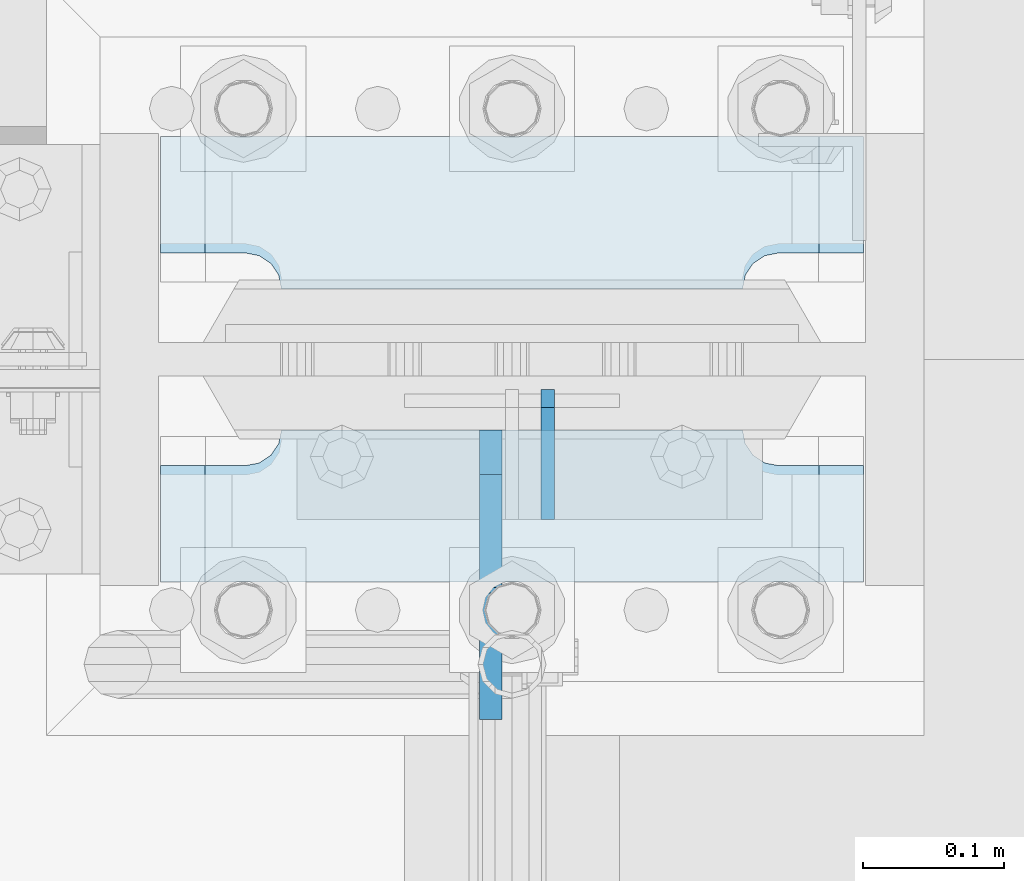
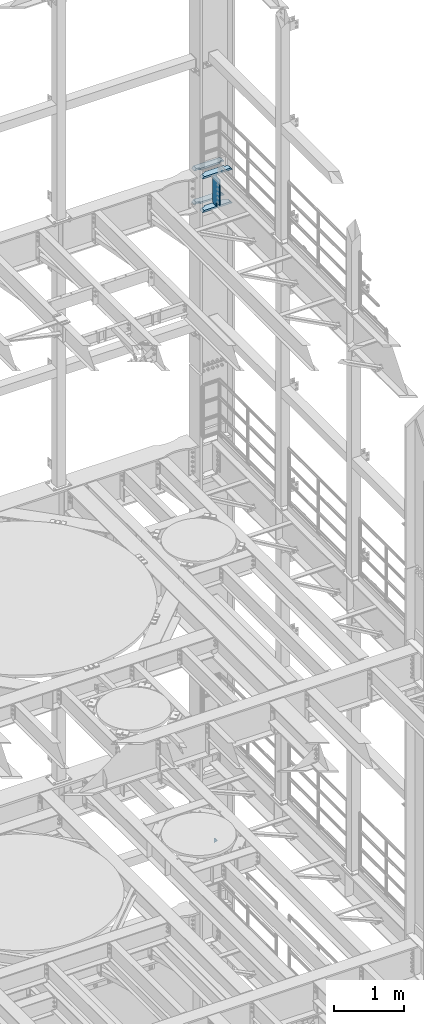
# One storey, part 1828 of 1876: 6 plates, 2 elements without a shape of their own.
"""IFC2X3 building model written with IfcOpenShell, lengths in millimetres."""

from ifc_helpers import new_model, si_unit, frame, origin_with_axes, place, context, subcontext, project, spatial, faceted_brep, material, type_object, element, aggregate, save


model = new_model("IFC2X3")

# Units and contexts
model_context = context("Model", 3, precision=1e-05, world=origin_with_axes())
body_context = subcontext(model_context, "Body", "Model", "MODEL_VIEW")
ifc_project = project(units=[si_unit("LENGTHUNIT", "METRE", prefix="MILLI"), si_unit("AREAUNIT", "SQUARE_METRE"), si_unit("VOLUMEUNIT", "CUBIC_METRE"), si_unit("MASSUNIT", "GRAM", prefix="KILO"), si_unit("TIMEUNIT", "SECOND"), si_unit("PLANEANGLEUNIT", "RADIAN"), si_unit("SOLIDANGLEUNIT", "STERADIAN"), si_unit("THERMODYNAMICTEMPERATUREUNIT", "DEGREE_CELSIUS"), si_unit("LUMINOUSINTENSITYUNIT", "LUMEN")], contexts=[model_context])

# Site, building, storey
site_placement = place(None, origin_with_axes())
site = spatial("IfcSite", under=ifc_project, at=site_placement, CompositionType="ELEMENT")
building_placement = place(site_placement, origin_with_axes())
building = spatial("IfcBuilding", under=site, at=building_placement, Name="Undefined", CompositionType="ELEMENT")
storey_placement = place(building_placement, origin_with_axes())
storey = spatial("IfcBuildingStorey", under=building, at=storey_placement, Name="Undefined", CompositionType="ELEMENT", Elevation=0.0)

# Assembly, plate
assembly_1_placement = place(storey_placement, origin_with_axes())
assembly_1 = element("IfcElementAssembly", 1, at=assembly_1_placement, inside=storey, Name="COLUMN", AssemblyPlace="NOTDEFINED", PredefinedType="RIGID_FRAME")
ifc_material_1 = material(Name="STEEL/A36")
plate_type_1 = type_object("IfcPlateType", PredefinedType="NOTDEFINED")
plate_1_placement = place(assembly_1_placement, frame((7645.4, 13602.4937494032, 6235.7), z_axis=(0.0, 0.707106781186548, 0.707106781186548), x_axis=(0.0, 0.707106781186548, -0.707106781186548)))
plate_1 = element("IfcPlate", 2, at=plate_1_placement, type_object=plate_type_1, material=ifc_material_1, Name="PLATE", context=body_context, shape_type="Brep", body=[
    faceted_brep([(0.0, -4.76249999999982, 0.0), (56.1266013136901, -4.76249999997708, 56.1266013135391), (56.1266013136883, 4.76250000002256, 56.1266013135428), (0.0, 4.76249999999982, 0.0), (74.0871132860975, -4.7624999999698, 56.1266013135246), (74.0871132860993, 4.76250000002983, 56.1266013135282), (130.213714599717, -4.76249999994707, -1.30967237055302e-10), (130.213714599715, 4.76250000005257, -1.23691279441118e-10)], [[[0, 1, 2, 3]], [[1, 4, 5, 2]], [[4, 6, 7, 5]], [[6, 0, 3, 7]], [[5, 7, 3, 2]], [[6, 4, 1, 0]]]),
])
aggregate(assembly_1, [plate_1])

# Assembly, plates
assembly_2_placement = place(storey_placement, origin_with_axes())
assembly_2 = element("IfcElementAssembly", 3, at=assembly_2_placement, inside=storey, Name="COLUMN", AssemblyPlace="NOTDEFINED", PredefinedType="RIGID_FRAME")
ifc_material_2 = material(Name="STEEL/A572-50")
plate_type_2 = type_object("IfcPlateType", PredefinedType="NOTDEFINED")
plate_2_placement = place(assembly_2_placement, frame((7370.7625, 13766.00625, 17376.775012207), z_axis=(1.0, 0.0, 0.0), x_axis=(0.0, 1.0, 0.0)))
plate_2 = element("IfcPlate", 4, at=plate_2_placement, type_object=plate_type_2, material=ifc_material_2, Name="PLATE", context=body_context, shape_type="Brep", body=[
    faceted_brep([(107.949996948242, -15.875, 498.475006103516), (107.949996948242, 15.875, 467.025007631571), (25.3999996185303, 15.875, 467.025007631571), (25.3999996185303, -15.875, 498.475006103516), (23.4665397733534, -15.875, 428.429848211837), (25.3999996185303, -15.875, 438.150007247925), (25.3999996185303, 15.875, 438.150007247925), (23.4665397733534, 15.875, 428.429848211837), (17.9605119723965, -15.875, 420.189495275529), (17.9605119723965, 15.875, 420.189495275529), (9.72015903608917, -15.875, 414.683467474573), (9.72015903608917, 15.875, 414.683467474573), (0.0, -15.875, 412.750007629395), (0.0, 15.875, 412.750007629395), (0.0, -15.875, 85.7249984741211), (0.0, 15.875, 85.7249984741211), (9.72015903609099, -15.875, 83.7915386289454), (9.72015903609099, 15.875, 83.7915386289454), (17.9605119723983, -15.875, 78.2855108279892), (17.9605119723983, 15.875, 78.2855108279892), (23.4665397733552, -15.875, 70.0451578916817), (23.4665397733552, 15.875, 70.0451578916817), (25.3999996185303, -15.875, 60.3249988555908), (25.3999996185303, 15.875, 60.3249988555908), (25.3999996185303, 15.875, 31.449998471945), (25.3999996185303, -15.875, 0.0), (107.949996948242, 15.875, 31.449998471945), (107.949996948242, -15.875, 0.0)], [[[0, 1, 2, 3]], [[4, 5, 6, 7]], [[8, 4, 7, 9]], [[10, 8, 9, 11]], [[12, 10, 11, 13]], [[14, 12, 13, 15]], [[16, 14, 15, 17]], [[18, 16, 17, 19]], [[20, 18, 19, 21]], [[22, 20, 21, 23]], [[22, 23, 24, 25]], [[26, 27, 25, 24]], [[5, 4, 8, 10, 12, 14, 16, 18, 20, 22, 25, 27, 0, 3]], [[6, 5, 3, 2]], [[26, 24, 23, 21, 19, 17, 15, 13, 11, 9, 7, 6, 2, 1]], [[27, 26, 1, 0]]]),
])
plate_3_placement = place(assembly_2_placement, frame((7370.7625, 13766.00625, 17967.325), z_axis=(1.0, 0.0, 0.0), x_axis=(0.0, 1.0, 0.0)))
plate_3 = element("IfcPlate", 5, at=plate_3_placement, type_object=plate_type_2, material=ifc_material_2, Name="PLATE", context=body_context, shape_type="Brep", body=[
    faceted_brep([(107.949996948242, -15.875, 498.475006103516), (107.949996948242, 15.875, 467.025007631571), (25.3999996185303, 15.875, 467.025007631571), (25.3999996185303, -15.875, 498.475006103516), (23.4665397733534, -15.875, 428.429848211837), (25.3999996185303, -15.875, 438.150007247925), (25.3999996185303, 15.875, 438.150007247925), (23.4665397733534, 15.875, 428.429848211837), (17.9605119723965, -15.875, 420.189495275529), (17.9605119723965, 15.875, 420.189495275529), (9.72015903608917, -15.875, 414.683467474573), (9.72015903608917, 15.875, 414.683467474573), (0.0, -15.875, 412.750007629395), (0.0, 15.875, 412.750007629395), (0.0, -15.875, 85.7249984741211), (0.0, 15.875, 85.7249984741211), (9.72015903609099, -15.875, 83.7915386289454), (9.72015903609099, 15.875, 83.7915386289454), (17.9605119723983, -15.875, 78.2855108279892), (17.9605119723983, 15.875, 78.2855108279892), (23.4665397733552, -15.875, 70.0451578916817), (23.4665397733552, 15.875, 70.0451578916817), (25.3999996185303, -15.875, 60.3249988555908), (25.3999996185303, 15.875, 60.3249988555908), (25.3999996185303, 15.875, 31.449998471945), (25.3999996185303, -15.875, 0.0), (107.949996948242, 15.875, 31.449998471945), (107.949996948242, -15.875, 0.0)], [[[0, 1, 2, 3]], [[4, 5, 6, 7]], [[8, 4, 7, 9]], [[10, 8, 9, 11]], [[12, 10, 11, 13]], [[14, 12, 13, 15]], [[16, 14, 15, 17]], [[18, 16, 17, 19]], [[20, 18, 19, 21]], [[22, 20, 21, 23]], [[22, 23, 24, 25]], [[26, 27, 25, 24]], [[5, 4, 8, 10, 12, 14, 16, 18, 20, 22, 25, 27, 0, 3]], [[6, 5, 3, 2]], [[26, 24, 23, 21, 19, 17, 15, 13, 11, 9, 7, 6, 2, 1]], [[27, 26, 1, 0]]]),
])
plate_4_placement = place(assembly_2_placement, frame((7370.7625, 13558.04375, 17376.775012207), z_axis=(1.0, 0.0, 0.0), x_axis=(0.0, 1.0, 0.0)))
plate_4 = element("IfcPlate", 6, at=plate_4_placement, type_object=plate_type_2, material=ifc_material_2, Name="PLATE", context=body_context, shape_type="Brep", body=[
    faceted_brep([(82.5499973297119, -15.875, 498.475006103516), (82.5499973297119, 15.875, 467.025007631571), (0.0, 15.875, 467.025007631571), (0.0, -15.875, 498.475006103516), (82.5499973297119, 15.875, 31.449998471945), (82.5499973297119, -15.875, 0.0), (0.0, -15.875, 0.0), (0.0, 15.875, 31.449998471945), (82.5499973297119, 15.875, 60.3249988555908), (82.5499973297119, -15.875, 60.3249988555908), (84.4834571748879, -15.875, 70.045157891682), (84.4834571748879, 15.875, 70.045157891682), (89.9894849758439, -15.875, 78.2855108279893), (89.9894849758439, 15.875, 78.2855108279893), (98.2298379121512, -15.875, 83.7915386289454), (98.2298379121512, 15.875, 83.7915386289454), (107.949996948242, -15.875, 85.7249984741211), (107.949996948242, 15.875, 85.7249984741211), (107.949996948242, -15.875, 412.750007629395), (107.949996948242, 15.875, 412.750007629395), (98.2298379121512, -15.875, 414.68346747457), (98.2298379121512, 15.875, 414.68346747457), (89.989484975843, -15.875, 420.189495275526), (89.989484975843, 15.875, 420.189495275526), (84.483457174887, -15.875, 428.429848211834), (84.483457174887, 15.875, 428.429848211834), (82.5499973297119, -15.875, 438.150007247925), (82.5499973297119, 15.875, 438.150007247925)], [[[0, 1, 2, 3]], [[4, 5, 6, 7]], [[8, 9, 5, 4]], [[10, 9, 8, 11]], [[12, 10, 11, 13]], [[14, 12, 13, 15]], [[16, 14, 15, 17]], [[18, 16, 17, 19]], [[20, 18, 19, 21]], [[22, 20, 21, 23]], [[24, 22, 23, 25]], [[26, 24, 25, 27]], [[6, 5, 9, 10, 12, 14, 16, 18, 20, 22, 24, 26, 0, 3]], [[7, 6, 3, 2]], [[27, 25, 23, 21, 19, 17, 15, 13, 11, 8, 4, 7, 2, 1]], [[26, 27, 1, 0]]]),
])
plate_5_placement = place(assembly_2_placement, frame((7370.7625, 13558.04375, 17967.325), z_axis=(1.0, 0.0, 0.0), x_axis=(0.0, 1.0, 0.0)))
plate_5 = element("IfcPlate", 7, at=plate_5_placement, type_object=plate_type_2, material=ifc_material_2, Name="PLATE", context=body_context, shape_type="Brep", body=[
    faceted_brep([(82.5499973297119, -15.875, 498.475006103516), (82.5499973297119, 15.875, 467.025007631571), (0.0, 15.875, 467.025007631571), (0.0, -15.875, 498.475006103516), (82.5499973297119, 15.875, 31.449998471945), (82.5499973297119, -15.875, 0.0), (0.0, -15.875, 0.0), (0.0, 15.875, 31.449998471945), (82.5499973297119, 15.875, 60.3249988555908), (82.5499973297119, -15.875, 60.3249988555908), (84.4834571748879, -15.875, 70.045157891682), (84.4834571748879, 15.875, 70.045157891682), (89.9894849758439, -15.875, 78.2855108279893), (89.9894849758439, 15.875, 78.2855108279893), (98.2298379121512, -15.875, 83.7915386289454), (98.2298379121512, 15.875, 83.7915386289454), (107.949996948242, -15.875, 85.7249984741211), (107.949996948242, 15.875, 85.7249984741211), (107.949996948242, -15.875, 412.750007629395), (107.949996948242, 15.875, 412.750007629395), (98.2298379121512, -15.875, 414.68346747457), (98.2298379121512, 15.875, 414.68346747457), (89.989484975843, -15.875, 420.189495275526), (89.989484975843, 15.875, 420.189495275526), (84.483457174887, -15.875, 428.429848211834), (84.483457174887, 15.875, 428.429848211834), (82.5499973297119, -15.875, 438.150007247925), (82.5499973297119, 15.875, 438.150007247925)], [[[0, 1, 2, 3]], [[4, 5, 6, 7]], [[8, 9, 5, 4]], [[10, 9, 8, 11]], [[12, 10, 11, 13]], [[14, 12, 13, 15]], [[16, 14, 15, 17]], [[18, 16, 17, 19]], [[20, 18, 19, 21]], [[22, 20, 21, 23]], [[24, 22, 23, 25]], [[26, 24, 25, 27]], [[6, 5, 9, 10, 12, 14, 16, 18, 20, 22, 24, 26, 0, 3]], [[7, 6, 3, 2]], [[27, 25, 23, 21, 19, 17, 15, 13, 11, 8, 4, 7, 2, 1]], [[26, 27, 1, 0]]]),
])
plate_type_3 = type_object("IfcPlateType", PredefinedType="NOTDEFINED")
plate_6_placement = place(assembly_2_placement, frame((7604.91875, 13665.99375, 17951.45), z_axis=(0.0, -1.0, 0.0), x_axis=(0.0, 0.0, -1.0)))
plate_6 = element("IfcPlate", 8, at=plate_6_placement, type_object=plate_type_3, material=ifc_material_1, Name="PLATE", context=body_context, shape_type="Brep", body=[
    faceted_brep([(488.949999999997, -7.93749999999998, 205.581253456207), (488.949999999997, -7.93749999999998, 120.649999809266), (488.949999999997, 7.93749999999999, 120.649999809266), (488.949999999997, 7.93749999999999, 205.581253051758), (489.916729922585, -7.93749999999998, 115.78992029122), (489.916729922585, 7.93749999999999, 115.78992029122), (492.669743823062, -7.93749999999998, 111.669743823067), (492.669743823062, 7.93749999999999, 111.669743823067), (496.789920291216, -7.93749999999998, 108.916729922588), (496.789920291216, 7.93749999999999, 108.916729922588), (501.649999809262, -7.93749999999998, 107.950000000001), (501.649999809262, 7.93749999999999, 107.950000000001), (558.799987792969, -7.93749999999998, 107.950000000001), (558.799987792969, 7.93749999999999, 107.950000000001), (31.7499984741225, -7.93749999999998, 205.581256103516), (31.7499984741225, 7.93749999999999, 205.581253051758), (31.7499984741225, 7.93749999999999, 120.649999809266), (31.7499984741225, -7.93749999999998, 120.649999809266), (30.783268551535, 7.93749999999999, 115.78992029122), (30.783268551535, -7.93749999999998, 115.78992029122), (28.0302546510575, 7.93749999999999, 111.669743823067), (28.0302546510575, -7.93749999999998, 111.669743823067), (23.9100781829038, 7.93749999999999, 108.916729922588), (23.9100781829038, -7.93749999999998, 108.916729922588), (19.0499986648574, 7.93749999999999, 107.950000000001), (19.0499986648574, -7.93749999999998, 107.950000000001), (0.0, 7.93749999999999, 107.950000000001), (0.0, -7.93749999999998, 107.950000000001), (0.0, 7.93749999999999, 31.75), (0.0, -7.93749999999998, 31.75), (31.75, -7.93749999999998, 0.0), (31.75, 7.93749999999999, 0.0), (527.049987792969, -7.93749999999998, 0.0), (527.049987792969, 7.93749999999999, 0.0), (558.799987792969, -7.93749999999998, 31.75), (558.799987792969, 7.93749999999999, 31.75)], [[[0, 1, 2, 3]], [[4, 5, 2, 1]], [[6, 7, 5, 4]], [[8, 9, 7, 6]], [[10, 11, 9, 8]], [[12, 13, 11, 10]], [[14, 15, 16, 17]], [[17, 16, 18, 19]], [[19, 18, 20, 21]], [[21, 20, 22, 23]], [[23, 22, 24, 25]], [[25, 24, 26, 27]], [[28, 29, 27, 26]], [[30, 29, 28, 31]], [[32, 30, 31, 33]], [[34, 32, 33, 35]], [[8, 6, 4, 1, 0, 14, 17, 19, 21, 23, 25, 27, 29, 30, 32, 34, 12, 10]], [[15, 14, 0, 3]], [[35, 33, 31, 28, 26, 24, 22, 20, 18, 16, 15, 3, 2, 5, 7, 9, 11, 13]], [[34, 35, 13, 12]]]),
])
aggregate(assembly_2, [plate_2, plate_3, plate_4, plate_5, plate_6])

save(model, "model.ifc")
